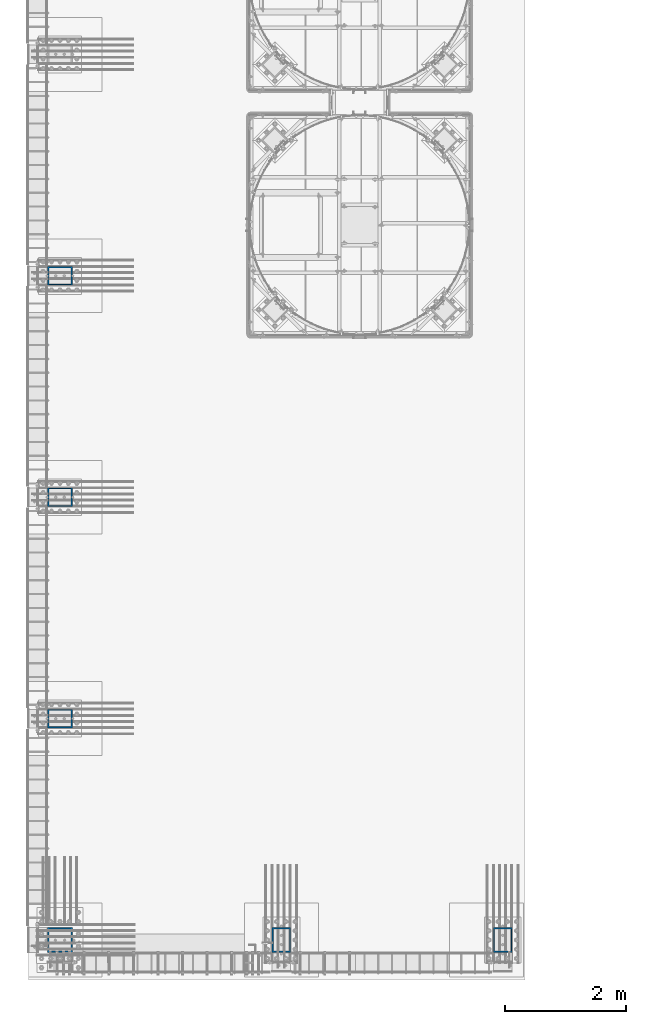
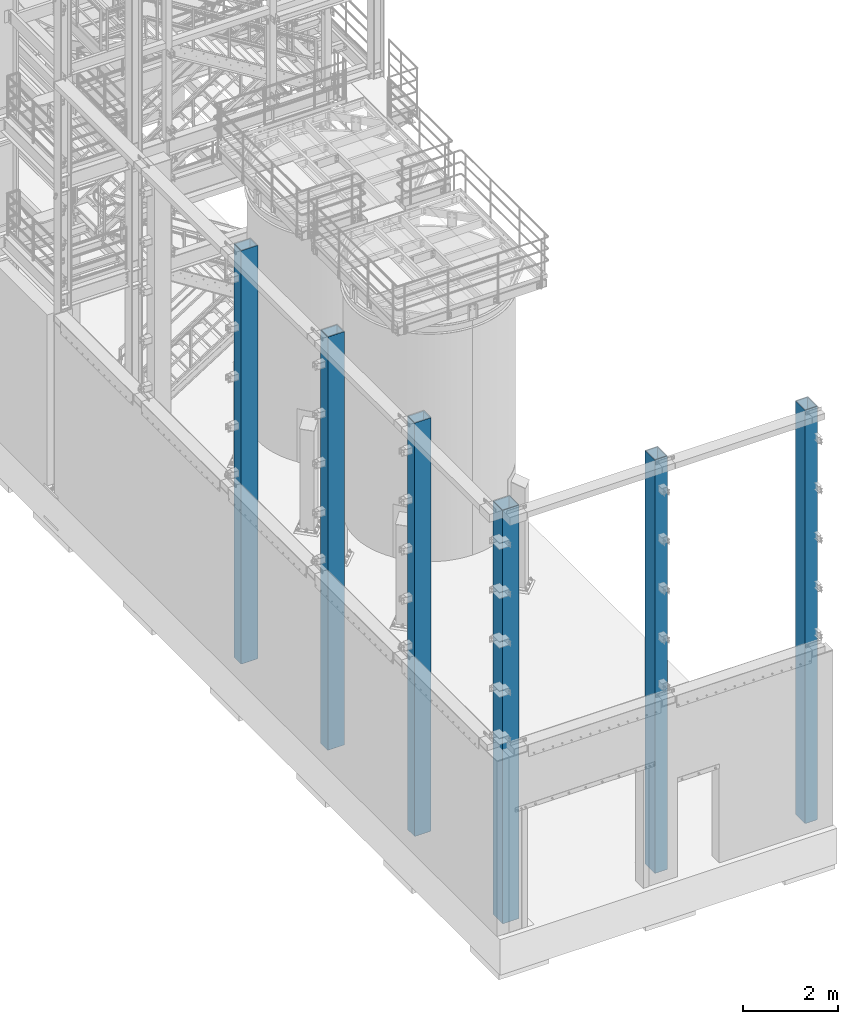
# One storey, part 540 of 1876: 6 columns, 6 elements without a shape of their own.
"""IFC2X3 building model written with IfcOpenShell, lengths in millimetres."""

from ifc_helpers import new_model, si_unit, frame, origin_with_axes, place, context, subcontext, project, spatial, faceted_brep, material, type_object, element, aggregate, save


model = new_model("IFC2X3")

# Units and contexts
model_context = context("Model", 3, precision=1e-05, world=origin_with_axes())
body_context = subcontext(model_context, "Body", "Model", "MODEL_VIEW")
ifc_project = project(units=[si_unit("LENGTHUNIT", "METRE", prefix="MILLI"), si_unit("AREAUNIT", "SQUARE_METRE"), si_unit("VOLUMEUNIT", "CUBIC_METRE"), si_unit("MASSUNIT", "GRAM", prefix="KILO"), si_unit("TIMEUNIT", "SECOND"), si_unit("PLANEANGLEUNIT", "RADIAN"), si_unit("SOLIDANGLEUNIT", "STERADIAN"), si_unit("THERMODYNAMICTEMPERATUREUNIT", "DEGREE_CELSIUS"), si_unit("LUMINOUSINTENSITYUNIT", "LUMEN")], contexts=[model_context])

# Site, building, storey
site_placement = place(None, origin_with_axes())
site = spatial("IfcSite", under=ifc_project, at=site_placement, CompositionType="ELEMENT")
building_placement = place(site_placement, origin_with_axes())
building = spatial("IfcBuilding", under=site, at=building_placement, Name="Undefined", CompositionType="ELEMENT")
storey_placement = place(building_placement, origin_with_axes())
storey = spatial("IfcBuildingStorey", under=building, at=storey_placement, Name="Undefined", CompositionType="ELEMENT", Elevation=0.0)

# Assembly, column
assembly_1_placement = place(storey_placement, origin_with_axes())
assembly_1 = element("IfcElementAssembly", 1, at=assembly_1_placement, inside=storey, Name="COLUMN", AssemblyPlace="NOTDEFINED", PredefinedType="RIGID_FRAME")
ifc_material = material()
column_type_1 = type_object("IfcColumnType", Name="HSS16X12X3/4", PredefinedType="NOTDEFINED")
column_1_placement = place(assembly_1_placement, frame((7546.975, -25400.0, 0.0), z_axis=(0.0, 1.0, 0.0), x_axis=(0.0, 0.0, 1.0)))
column_1 = element("IfcColumn", 2, at=column_1_placement, type_object=column_type_1, material=ifc_material, Name="COLUMN", ObjectType="HSS16X12X3/4", context=body_context, shape_type="Brep", body=[
    faceted_brep([(19.0499999999975, 152.4, 203.200000000001), (19.0499999999993, 152.4, -203.200000000001), (0.0, 133.35, -184.150000000001), (0.0, 133.35, 184.150000000001), (19.0499999999993, -152.4, -203.200000000001), (0.0, -133.35, -184.150000000001), (19.0499999999991, -152.399999999999, 203.200000000001), (0.0, -133.35, 184.150000000001), (10658.475, -152.4, 203.200000000001), (10658.475, 152.4, 203.200000000001), (10658.475, -152.4, -203.200000000001), (10658.475, 152.4, -203.200000000001), (10658.475, -133.35, 184.150000000001), (10658.475, 133.35, 184.150000000001), (10658.475, 133.35, -184.150000000001), (10658.475, -133.35, -184.150000000001)], [[[0, 1, 2, 3]], [[4, 5, 2, 1]], [[6, 7, 5, 4]], [[8, 9, 0, 6]], [[10, 8, 6, 4]], [[11, 10, 4, 1]], [[9, 11, 1, 0]], [[8, 10, 11, 9], [12, 13, 14, 15]], [[14, 13, 3, 2]], [[15, 14, 2, 5]], [[12, 15, 5, 7]], [[13, 12, 7, 3]], [[0, 3, 7, 6]]]),
])
aggregate(assembly_1, [column_1])

assembly_2_placement = place(storey_placement, origin_with_axes())
assembly_2 = element("IfcElementAssembly", 3, at=assembly_2_placement, inside=storey, Name="COLUMN", AssemblyPlace="NOTDEFINED", PredefinedType="RIGID_FRAME")
column_2_placement = place(assembly_2_placement, frame((3889.375, -25400.0, 0.0), z_axis=(0.0, 1.0, 0.0), x_axis=(0.0, 0.0, 1.0)))
column_2 = element("IfcColumn", 4, at=column_2_placement, type_object=column_type_1, material=ifc_material, Name="COLUMN", ObjectType="HSS16X12X3/4", context=body_context, shape_type="Brep", body=[
    faceted_brep([(19.0499999999975, 152.4, 203.200000000001), (19.0499999999993, 152.4, -203.200000000001), (0.0, 133.35, -184.150000000001), (0.0, 133.35, 184.150000000001), (19.0499999999993, -152.4, -203.200000000001), (0.0, -133.35, -184.150000000001), (19.0499999999991, -152.399999999999, 203.200000000001), (0.0, -133.35, 184.150000000001), (10658.475, -152.4, 203.200000000001), (10658.475, 152.4, 203.200000000001), (10658.475, -152.4, -203.200000000001), (10658.475, 152.4, -203.200000000001), (10658.475, -133.35, 184.150000000001), (10658.475, 133.35, 184.150000000001), (10658.475, 133.35, -184.150000000001), (10658.475, -133.35, -184.150000000001)], [[[0, 1, 2, 3]], [[4, 5, 2, 1]], [[6, 7, 5, 4]], [[8, 9, 0, 6]], [[10, 8, 6, 4]], [[11, 10, 4, 1]], [[9, 11, 1, 0]], [[8, 10, 11, 9], [12, 13, 14, 15]], [[14, 13, 3, 2]], [[15, 14, 2, 5]], [[12, 15, 5, 7]], [[13, 12, 7, 3]], [[0, 3, 7, 6]]]),
])
aggregate(assembly_2, [column_2])

assembly_3_placement = place(storey_placement, origin_with_axes())
assembly_3 = element("IfcElementAssembly", 5, at=assembly_3_placement, inside=storey, Name="COLUMN", AssemblyPlace="NOTDEFINED", PredefinedType="RIGID_FRAME")
column_3_placement = place(assembly_3_placement, frame((231.774999999999, -21742.4, 0.0), z_axis=(-1.0, 0.0, 0.0), x_axis=(0.0, 0.0, 1.0)))
column_3 = element("IfcColumn", 6, at=column_3_placement, type_object=column_type_1, material=ifc_material, Name="COLUMN", ObjectType="HSS16X12X3/4", context=body_context, shape_type="Brep", body=[
    faceted_brep([(19.0499999999975, 152.4, 203.200000000001), (19.0499999999993, 152.4, -203.200000000001), (0.0, 133.35, -184.150000000001), (0.0, 133.35, 184.150000000001), (19.0499999999993, -152.4, -203.200000000001), (0.0, -133.35, -184.150000000001), (19.0499999999991, -152.399999999999, 203.200000000001), (0.0, -133.35, 184.150000000001), (10658.475, -152.4, 203.200000000001), (10658.475, 152.4, 203.200000000001), (10658.475, -152.4, -203.200000000001), (10658.475, 152.4, -203.200000000001), (10658.475, -133.35, 184.150000000001), (10658.475, 133.35, 184.150000000001), (10658.475, 133.35, -184.150000000001), (10658.475, -133.35, -184.150000000001)], [[[0, 1, 2, 3]], [[4, 5, 2, 1]], [[6, 7, 5, 4]], [[8, 9, 0, 6]], [[10, 8, 6, 4]], [[11, 10, 4, 1]], [[9, 11, 1, 0]], [[8, 10, 11, 9], [12, 13, 14, 15]], [[14, 13, 3, 2]], [[15, 14, 2, 5]], [[12, 15, 5, 7]], [[13, 12, 7, 3]], [[0, 3, 7, 6]]]),
])
aggregate(assembly_3, [column_3])

assembly_4_placement = place(storey_placement, origin_with_axes())
assembly_4 = element("IfcElementAssembly", 7, at=assembly_4_placement, inside=storey, Name="COLUMN", AssemblyPlace="NOTDEFINED", PredefinedType="RIGID_FRAME")
column_4_placement = place(assembly_4_placement, frame((231.774999999999, -18084.8, 0.0), z_axis=(-1.0, 0.0, 0.0), x_axis=(0.0, 0.0, 1.0)))
column_4 = element("IfcColumn", 8, at=column_4_placement, type_object=column_type_1, material=ifc_material, Name="COLUMN", ObjectType="HSS16X12X3/4", context=body_context, shape_type="Brep", body=[
    faceted_brep([(19.0499999999975, 152.4, 203.200000000001), (19.0499999999993, 152.4, -203.200000000001), (0.0, 133.35, -184.150000000001), (0.0, 133.35, 184.150000000001), (19.0499999999993, -152.4, -203.200000000001), (0.0, -133.35, -184.150000000001), (19.0499999999991, -152.399999999999, 203.200000000001), (0.0, -133.35, 184.150000000001), (10658.475, -152.4, 203.200000000001), (10658.475, 152.4, 203.200000000001), (10658.475, -152.4, -203.200000000001), (10658.475, 152.4, -203.200000000001), (10658.475, -133.35, 184.150000000001), (10658.475, 133.35, 184.150000000001), (10658.475, 133.35, -184.150000000001), (10658.475, -133.35, -184.150000000001)], [[[0, 1, 2, 3]], [[4, 5, 2, 1]], [[6, 7, 5, 4]], [[8, 9, 0, 6]], [[10, 8, 6, 4]], [[11, 10, 4, 1]], [[9, 11, 1, 0]], [[8, 10, 11, 9], [12, 13, 14, 15]], [[14, 13, 3, 2]], [[15, 14, 2, 5]], [[12, 15, 5, 7]], [[13, 12, 7, 3]], [[0, 3, 7, 6]]]),
])
aggregate(assembly_4, [column_4])

assembly_5_placement = place(storey_placement, origin_with_axes())
assembly_5 = element("IfcElementAssembly", 9, at=assembly_5_placement, inside=storey, Name="COLUMN", AssemblyPlace="NOTDEFINED", PredefinedType="RIGID_FRAME")
column_5_placement = place(assembly_5_placement, frame((231.774999999999, -14427.2, 0.0), z_axis=(-1.0, 0.0, 0.0), x_axis=(0.0, 0.0, 1.0)))
column_5 = element("IfcColumn", 10, at=column_5_placement, type_object=column_type_1, material=ifc_material, Name="COLUMN", ObjectType="HSS16X12X3/4", context=body_context, shape_type="Brep", body=[
    faceted_brep([(19.0499999999975, 152.4, 203.200000000001), (19.0499999999993, 152.4, -203.200000000001), (0.0, 133.35, -184.150000000001), (0.0, 133.35, 184.150000000001), (19.0499999999993, -152.4, -203.200000000001), (0.0, -133.35, -184.150000000001), (19.0499999999991, -152.399999999999, 203.200000000001), (0.0, -133.35, 184.150000000001), (10658.475, -152.4, 203.200000000001), (10658.475, 152.4, 203.200000000001), (10658.475, -152.4, -203.200000000001), (10658.475, 152.4, -203.200000000001), (10658.475, -133.35, 184.150000000001), (10658.475, 133.35, 184.150000000001), (10658.475, 133.35, -184.150000000001), (10658.475, -133.35, -184.150000000001)], [[[0, 1, 2, 3]], [[4, 5, 2, 1]], [[6, 7, 5, 4]], [[8, 9, 0, 6]], [[10, 8, 6, 4]], [[11, 10, 4, 1]], [[9, 11, 1, 0]], [[8, 10, 11, 9], [12, 13, 14, 15]], [[14, 13, 3, 2]], [[15, 14, 2, 5]], [[12, 15, 5, 7]], [[13, 12, 7, 3]], [[0, 3, 7, 6]]]),
])
aggregate(assembly_5, [column_5])

assembly_6_placement = place(storey_placement, origin_with_axes())
assembly_6 = element("IfcElementAssembly", 11, at=assembly_6_placement, inside=storey, Name="COLUMN", AssemblyPlace="NOTDEFINED", PredefinedType="RIGID_FRAME")
column_type_2 = type_object("IfcColumnType", Name="HSS16X16X3/4", PredefinedType="NOTDEFINED")
column_6_placement = place(assembly_6_placement, frame((231.774999999999, -25400.0, 0.0), z_axis=(-1.0, 0.0, 0.0), x_axis=(0.0, 0.0, 1.0)))
column_6 = element("IfcColumn", 12, at=column_6_placement, type_object=column_type_2, material=ifc_material, Name="COLUMN", ObjectType="HSS16X16X3/4", context=body_context, shape_type="Brep", body=[
    faceted_brep([(19.0499999999993, 203.200000000001, 203.2), (19.0499999999993, 203.200000000001, -203.2), (0.0, 184.150000000001, -184.15), (0.0, 184.150000000001, 184.15), (19.0499999999993, -203.200000000001, -203.2), (0.0, -184.150000000001, -184.15), (19.0499999999998, -203.200000000001, 203.2), (0.0, -184.150000000001, 184.15), (10658.475, -203.200000000001, 203.2), (10658.475, 203.200000000001, 203.2), (10658.475, -203.200000000001, -203.2), (10658.475, 203.200000000001, -203.2), (10658.475, -184.150000000001, 184.15), (10658.475, 184.150000000001, 184.15), (10658.475, 184.150000000001, -184.15), (10658.475, -184.150000000001, -184.15)], [[[0, 1, 2, 3]], [[4, 5, 2, 1]], [[6, 7, 5, 4]], [[8, 9, 0, 6]], [[10, 8, 6, 4]], [[11, 10, 4, 1]], [[9, 11, 1, 0]], [[8, 10, 11, 9], [12, 13, 14, 15]], [[14, 13, 3, 2]], [[15, 14, 2, 5]], [[12, 15, 5, 7]], [[13, 12, 7, 3]], [[0, 3, 7, 6]]]),
])
aggregate(assembly_6, [column_6])

save(model, "model.ifc")
